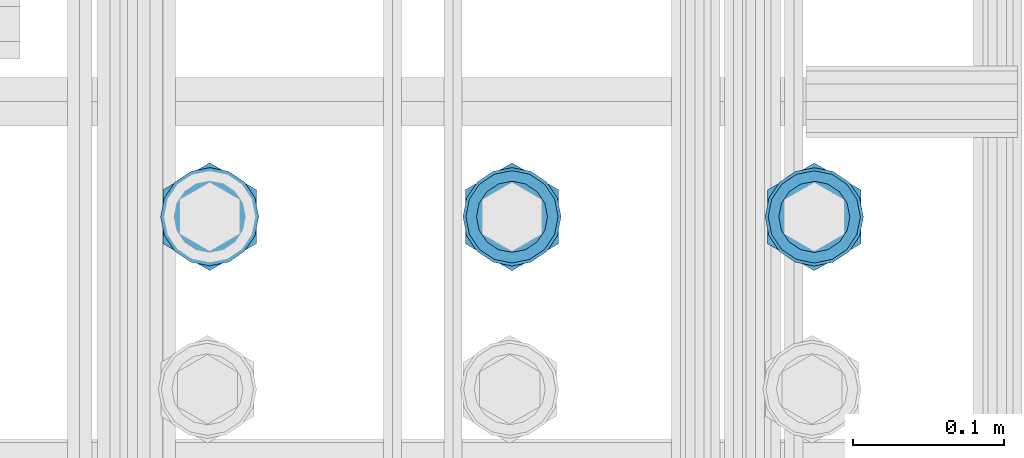
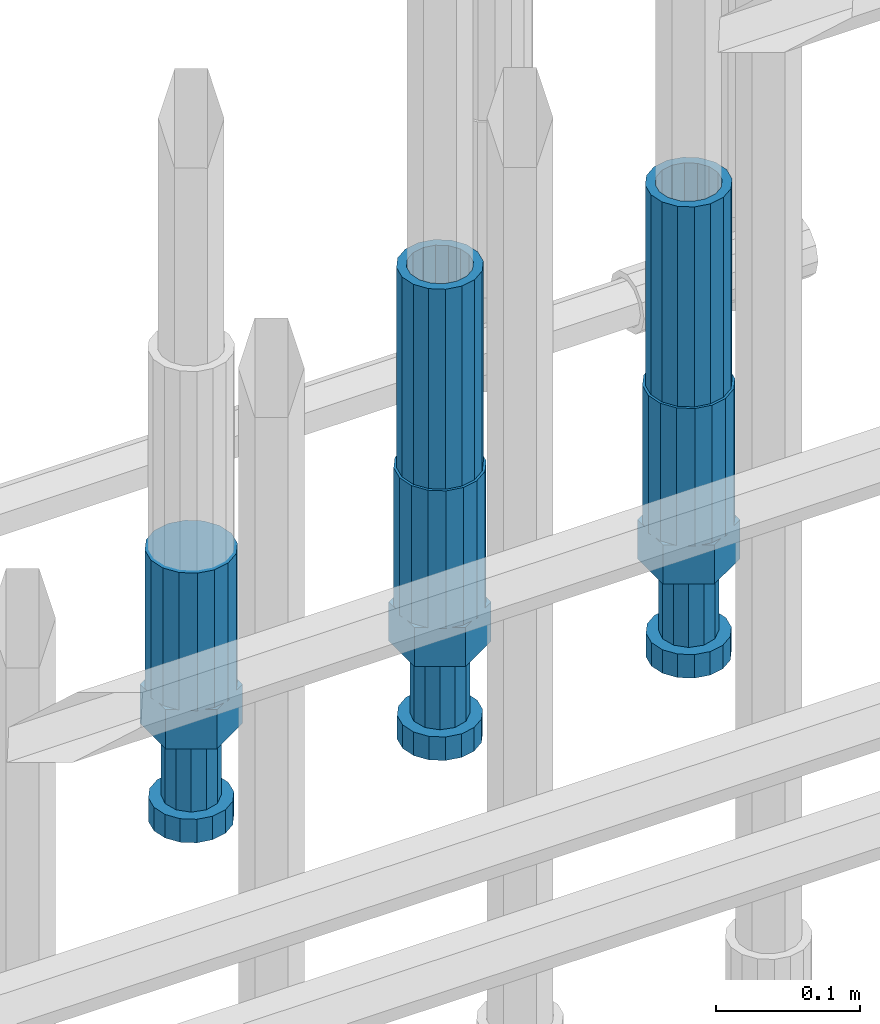
# One storey, part 41 of 177: 5 beams.
"""IFC2X3 building model written with IfcOpenShell, lengths in millimetres."""

from ifc_helpers import new_model, si_unit, frame, origin_with_axes, place, context, subcontext, project, spatial, faceted_brep, material, type_object, element, save


model = new_model("IFC2X3")

# Units and contexts
model_context_1 = context("Model", 3, precision=1e-05, world=origin_with_axes())
model_context_2 = context("Model", 3, precision=1e-05, world=origin_with_axes())
body_context = subcontext(model_context_2, "Body", "Model", "MODEL_VIEW")
ifc_project = project(units=[si_unit("LENGTHUNIT", "METRE", prefix="MILLI"), si_unit("AREAUNIT", "SQUARE_METRE"), si_unit("VOLUMEUNIT", "CUBIC_METRE"), si_unit("MASSUNIT", "GRAM", prefix="KILO"), si_unit("TIMEUNIT", "SECOND"), si_unit("PLANEANGLEUNIT", "RADIAN"), si_unit("SOLIDANGLEUNIT", "STERADIAN"), si_unit("THERMODYNAMICTEMPERATUREUNIT", "DEGREE_CELSIUS"), si_unit("LUMINOUSINTENSITYUNIT", "LUMEN")], contexts=[model_context_1])

# Site, building, storey
site_placement = place(None, origin_with_axes())
site = spatial("IfcSite", under=ifc_project, at=site_placement, CompositionType="ELEMENT")
building_placement = place(site_placement, origin_with_axes())
building = spatial("IfcBuilding", under=site, at=building_placement, Name="Undefined", CompositionType="ELEMENT")
storey_placement = place(building_placement, origin_with_axes())
storey = spatial("IfcBuildingStorey", under=building, at=storey_placement, Name="Undefined", CompositionType="ELEMENT", Elevation=0.0)

# Beams
ifc_material = material(Name="STEEL/S275")
beam_type_1 = type_object("IfcBeamType", PredefinedType="NOTDEFINED")
beam_1_placement = place(storey_placement, frame((2031575.50320246, 6205271.46363198, 19060.9768004271), z_axis=(-1.0, 0.0, 0.0), x_axis=(0.0, 0.0, -1.0)))
element("IfcBeam", 1, at=beam_1_placement, inside=storey, type_object=beam_type_1, material=ifc_material, Name="AG40N", context=body_context, shape_type="Brep", body=[
    faceted_brep([(0.0, -23.5000000001164, -9.31322574615479e-10), (0.0, -21.7111690140155, 8.99306066054851), (170.0, -21.7111690140155, 8.99306066054851), (170.0, -23.5, 0.0), (0.0, -16.6170093578839, 16.6170093575493), (170.0, -16.6170093578839, 16.6170093575493), (0.0, -8.99306066057943, 21.7111690137535), (170.0, -8.99306066057943, 21.7111690137535), (0.0, 1.16415321826935e-10, 23.5), (170.0, 0.0, 23.5), (0.0, 8.99306066057943, 21.7111690137535), (170.0, 8.99306066057943, 21.7111690137535), (0.0, 16.6170093578839, 16.6170093575493), (170.0, 16.6170093578839, 16.6170093575493), (0.0, 21.7111690140155, 8.99306066054851), (170.0, 21.7111690140155, 8.99306066054851), (0.0, 23.5000000001164, -9.31322574615479e-10), (170.0, 23.5, 0.0), (0.0, 21.7111690140155, -8.99306066054851), (170.0, 21.7111690140155, -8.99306066054851), (0.0, 16.6170093578839, -16.6170093575493), (170.0, 16.6170093578839, -16.6170093575493), (0.0, 8.99306066057943, -21.7111690137535), (170.0, 8.99306066057943, -21.7111690137535), (0.0, 1.16415321826935e-10, -23.5000000009313), (170.0, 0.0, -23.5), (0.0, -8.99306066057943, -21.7111690137535), (170.0, -8.99306066057943, -21.7111690137535), (0.0, -16.6170093578839, -16.6170093575493), (170.0, -16.6170093578839, -16.6170093575493), (0.0, -21.7111690140155, -8.99306066054851), (170.0, -21.7111690140155, -8.99306066054851), (0.0, -30.5, 0.0), (0.0, -28.1783257415937, -11.6718446873128), (170.0, -28.1783257415937, -11.6718446873128), (170.0, -30.5, 0.0), (0.0, -21.5667568261888, -21.5667568258941), (170.0, -21.5667568261888, -21.5667568258941), (0.0, -11.6718446871346, -28.1783257415518), (170.0, -11.6718446871346, -28.1783257415518), (0.0, 0.0, -30.5), (170.0, 0.0, -30.5), (0.0, 11.6718446871346, -28.1783257415518), (170.0, 11.6718446871346, -28.1783257415518), (0.0, 21.5667568261888, -21.5667568258941), (170.0, 21.5667568261888, -21.5667568258941), (0.0, 28.1783257415937, -11.6718446873128), (170.0, 28.1783257415937, -11.6718446873128), (0.0, 30.5, 0.0), (170.0, 30.5, 0.0), (0.0, 28.1783257415937, 11.6718446873128), (170.0, 28.1783257415937, 11.6718446873128), (0.0, 21.5667568261888, 21.5667568258941), (170.0, 21.5667568261888, 21.5667568258941), (0.0, 11.6718446871346, 28.1783257415518), (170.0, 11.6718446871346, 28.1783257415518), (0.0, 0.0, 30.5), (170.0, 0.0, 30.5), (0.0, -11.6718446871346, 28.1783257415518), (170.0, -11.6718446871346, 28.1783257415518), (0.0, -21.5667568261888, 21.5667568258941), (170.0, -21.5667568261888, 21.5667568258941), (0.0, -28.1783257415937, 11.6718446873128), (170.0, -28.1783257415937, 11.6718446873128)], [[[0, 1, 2, 3]], [[1, 4, 5, 2]], [[4, 6, 7, 5]], [[6, 8, 9, 7]], [[8, 10, 11, 9]], [[10, 12, 13, 11]], [[12, 14, 15, 13]], [[14, 16, 17, 15]], [[16, 18, 19, 17]], [[18, 20, 21, 19]], [[20, 22, 23, 21]], [[22, 24, 25, 23]], [[24, 26, 27, 25]], [[26, 28, 29, 27]], [[28, 30, 31, 29]], [[30, 0, 3, 31]], [[32, 33, 34, 35]], [[33, 36, 37, 34]], [[36, 38, 39, 37]], [[38, 40, 41, 39]], [[40, 42, 43, 41]], [[42, 44, 45, 43]], [[44, 46, 47, 45]], [[46, 48, 49, 47]], [[48, 50, 51, 49]], [[50, 52, 53, 51]], [[52, 54, 55, 53]], [[54, 56, 57, 55]], [[56, 58, 59, 57]], [[58, 60, 61, 59]], [[60, 62, 63, 61]], [[62, 32, 35, 63]], [[37, 39, 41, 43, 45, 47, 49, 51, 53, 55, 57, 59, 61, 63, 35, 34], [5, 7, 9, 11, 13, 15, 17, 19, 21, 23, 25, 27, 29, 31, 3, 2]], [[62, 60, 58, 56, 54, 52, 50, 48, 46, 44, 42, 40, 38, 36, 33, 32], [30, 28, 26, 24, 22, 20, 18, 16, 14, 12, 10, 8, 6, 4, 1, 0]]]),
])
beam_2_placement = place(storey_placement, frame((2031775.50319529, 6205271.41014018, 19060.9768004269), z_axis=(-1.0, 0.0, 0.0), x_axis=(0.0, 0.0, -1.0)))
element("IfcBeam", 2, at=beam_2_placement, inside=storey, type_object=beam_type_1, material=ifc_material, Name="AG40N", context=body_context, shape_type="Brep", body=[
    faceted_brep([(0.0, -23.5000000001164, -9.31322574615479e-10), (0.0, -21.7111690140155, 8.99306066054851), (170.0, -21.7111690140155, 8.99306066054851), (170.0, -23.5, 0.0), (0.0, -16.6170093578839, 16.6170093575493), (170.0, -16.6170093578839, 16.6170093575493), (0.0, -8.99306066057943, 21.7111690137535), (170.0, -8.99306066057943, 21.7111690137535), (0.0, 1.16415321826935e-10, 23.5), (170.0, 0.0, 23.5), (0.0, 8.99306066057943, 21.7111690137535), (170.0, 8.99306066057943, 21.7111690137535), (0.0, 16.6170093578839, 16.6170093575493), (170.0, 16.6170093578839, 16.6170093575493), (0.0, 21.7111690140155, 8.99306066054851), (170.0, 21.7111690140155, 8.99306066054851), (0.0, 23.5000000001164, -9.31322574615479e-10), (170.0, 23.5, 0.0), (0.0, 21.7111690140155, -8.99306066054851), (170.0, 21.7111690140155, -8.99306066054851), (0.0, 16.6170093578839, -16.6170093575493), (170.0, 16.6170093578839, -16.6170093575493), (0.0, 8.99306066057943, -21.7111690137535), (170.0, 8.99306066057943, -21.7111690137535), (0.0, 1.16415321826935e-10, -23.5000000009313), (170.0, 0.0, -23.5), (0.0, -8.99306066057943, -21.7111690137535), (170.0, -8.99306066057943, -21.7111690137535), (0.0, -16.6170093578839, -16.6170093575493), (170.0, -16.6170093578839, -16.6170093575493), (0.0, -21.7111690140155, -8.99306066054851), (170.0, -21.7111690140155, -8.99306066054851), (0.0, -30.5, 0.0), (0.0, -28.1783257415937, -11.6718446873128), (170.0, -28.1783257415937, -11.6718446873128), (170.0, -30.5, 0.0), (0.0, -21.5667568261888, -21.5667568258941), (170.0, -21.5667568261888, -21.5667568258941), (0.0, -11.6718446871346, -28.1783257415518), (170.0, -11.6718446871346, -28.1783257415518), (0.0, 0.0, -30.5), (170.0, 0.0, -30.5), (0.0, 11.6718446871346, -28.1783257415518), (170.0, 11.6718446871346, -28.1783257415518), (0.0, 21.5667568261888, -21.5667568258941), (170.0, 21.5667568261888, -21.5667568258941), (0.0, 28.1783257415937, -11.6718446873128), (170.0, 28.1783257415937, -11.6718446873128), (0.0, 30.5, 0.0), (170.0, 30.5, 0.0), (0.0, 28.1783257415937, 11.6718446873128), (170.0, 28.1783257415937, 11.6718446873128), (0.0, 21.5667568261888, 21.5667568258941), (170.0, 21.5667568261888, 21.5667568258941), (0.0, 11.6718446871346, 28.1783257415518), (170.0, 11.6718446871346, 28.1783257415518), (0.0, 0.0, 30.5), (170.0, 0.0, 30.5), (0.0, -11.6718446871346, 28.1783257415518), (170.0, -11.6718446871346, 28.1783257415518), (0.0, -21.5667568261888, 21.5667568258941), (170.0, -21.5667568261888, 21.5667568258941), (0.0, -28.1783257415937, 11.6718446873128), (170.0, -28.1783257415937, 11.6718446873128)], [[[0, 1, 2, 3]], [[1, 4, 5, 2]], [[4, 6, 7, 5]], [[6, 8, 9, 7]], [[8, 10, 11, 9]], [[10, 12, 13, 11]], [[12, 14, 15, 13]], [[14, 16, 17, 15]], [[16, 18, 19, 17]], [[18, 20, 21, 19]], [[20, 22, 23, 21]], [[22, 24, 25, 23]], [[24, 26, 27, 25]], [[26, 28, 29, 27]], [[28, 30, 31, 29]], [[30, 0, 3, 31]], [[32, 33, 34, 35]], [[33, 36, 37, 34]], [[36, 38, 39, 37]], [[38, 40, 41, 39]], [[40, 42, 43, 41]], [[42, 44, 45, 43]], [[44, 46, 47, 45]], [[46, 48, 49, 47]], [[48, 50, 51, 49]], [[50, 52, 53, 51]], [[52, 54, 55, 53]], [[54, 56, 57, 55]], [[56, 58, 59, 57]], [[58, 60, 61, 59]], [[60, 62, 63, 61]], [[62, 32, 35, 63]], [[37, 39, 41, 43, 45, 47, 49, 51, 53, 55, 57, 59, 61, 63, 35, 34], [5, 7, 9, 11, 13, 15, 17, 19, 21, 23, 25, 27, 29, 31, 3, 2]], [[62, 60, 58, 56, 54, 52, 50, 48, 46, 44, 42, 40, 38, 36, 33, 32], [30, 28, 26, 24, 22, 20, 18, 16, 14, 12, 10, 8, 6, 4, 1, 0]]]),
])
beam_type_2 = type_object("IfcBeamType", Name="ROD65", PredefinedType="NOTDEFINED")
beam_3_placement = place(storey_placement, frame((2031375.50320962, 6205271.51712378, 18890.9768004272), z_axis=(-1.0, 0.0, 0.0), x_axis=(0.0, 0.0, -1.0)))
element("IfcBeam", 3, at=beam_3_placement, inside=storey, type_object=beam_type_2, material=ifc_material, Name="AGB40", ObjectType="ROD65", context=body_context, shape_type="Brep", body=[
    faceted_brep([(117.0, 8.17543110251427, 30.873805644922), (117.0, 17.8250000001863, 30.873805644922), (117.0, 22.0056958701462, 23.6326279877685), (117.0, 12.4372115517035, 30.0260848065373), (117.0, -17.8250000001863, 30.873805644922), (150.200000000186, -17.8250000001863, 30.873805644922), (150.200000000186, 17.8250000001863, 30.873805644922), (117.0, -8.17543110251427, 30.873805644922), (117.0, -12.4372115517035, 30.0260848065373), (117.0, -22.0056958701462, 23.6326279877685), (117.0, -35.6500000003725, 0.0), (150.200000000186, -35.6500000003725, 0.0), (117.0, -30.8443150008097, 8.32369058486074), (117.0, -32.5, 0.0), (117.0, -30.8443150008097, -8.32369058462791), (117.0, -17.8250000001863, -30.873805644922), (150.200000000186, -17.8250000001863, -30.873805644922), (117.0, -22.0056958701462, -23.6326279877685), (117.0, -12.4372115517035, -30.0260848065373), (117.0, -8.17543110251427, -30.873805644922), (117.0, 17.8250000001863, -30.873805644922), (150.200000000186, 17.8250000001863, -30.873805644922), (117.0, 8.17543110251427, -30.873805644922), (117.0, 22.0056958701462, -23.6326279877685), (117.0, 12.4372115517035, -30.0260848065373), (117.0, 35.6500000003725, 0.0), (150.200000000186, 35.6500000003725, 0.0), (117.0, 30.8443150008097, -8.32369058486074), (117.0, 30.8443150008097, 8.32369058462791), (117.0, 32.5, 0.0), (0.0, -22.9809703892097, 22.9809703885621), (0.0, -30.0260848058388, 12.4372115518636), (117.0, -30.0260848067701, 12.4372115519363), (117.0, -22.9809703882784, 22.9809703885112), (-2.3283064365387e-10, 22.9809703892097, -22.9809703885639), (-4.65661287307739e-10, 30.0260848077014, -12.4372115518672), (117.0, 30.0260848067701, -12.4372115519363), (117.0, 22.9809703882784, -22.9809703885112), (-2.3283064365387e-10, -30.0260848067701, -12.4372115518672), (-2.3283064365387e-10, -22.9809703892097, -22.9809703885621), (117.0, -22.9809703882784, -22.9809703885112), (117.0, -30.0260848067701, -12.4372115519363), (-2.3283064365387e-10, -12.4372115507722, 30.0260848066137), (-2.3283064365387e-10, 9.31322574615479e-10, 32.4999999999982), (-2.3283064365387e-10, 12.4372115526348, 30.0260848066137), (0.0, 22.9809703892097, 22.9809703885621), (-2.3283064365387e-10, 30.0260848077014, 12.4372115518636), (-2.3283064365387e-10, 32.5, 0.0), (-2.3283064365387e-10, 12.4372115526348, -30.0260848066173), (-2.3283064365387e-10, 9.31322574615479e-10, -32.5), (-2.3283064365387e-10, -12.4372115517035, -30.0260848066173), (-4.65661287307739e-10, -32.4999999990687, -1.81898940354586e-12), (117.0, 22.9809703882784, 22.9809703885112), (117.0, 30.0260848067701, 12.4372115519363), (117.0, 0.0, -32.5), (117.0, 0.0, 32.5), (150.200000000186, 10.5, -18.1865334794857), (150.200000000186, 0.0, -21.0), (150.200000000186, -10.5, -18.1865334794857), (150.200000000186, -18.18653347902, -10.5), (150.200000000186, -21.0, 0.0), (150.200000000186, -18.18653347902, 10.5), (150.200000000186, -10.5, 18.1865334794857), (150.200000000186, 0.0, 21.0), (150.200000000186, 10.5, 18.1865334794857), (150.200000000186, 18.18653347902, 10.5), (150.200000000186, 21.0, 0.0), (150.200000000186, 18.18653347902, -10.5), (210.980000000447, -10.5, -18.1865334794857), (210.980000000447, 0.0, -21.0), (210.980000000447, -18.18653347902, -10.5), (210.980000000447, -21.0, 0.0), (210.980000000447, -18.18653347902, 10.5), (210.980000000447, -10.5, 18.1865334794857), (210.980000000447, 0.0, 21.0), (210.980000000447, 10.5, 18.1865334794857), (210.980000000447, 18.18653347902, 10.5), (210.980000000447, 21.0, 0.0), (210.980000000447, 18.18653347902, -10.5), (210.980000000447, 10.5, -18.1865334794857), (211.001368442696, -27.7269937992096, -11.491116326768), (211.003082550167, -21.2238094303757, -21.223815418547), (231.002518367059, -21.2131944671273, -21.2132004550658), (231.000804259587, -27.7163788359612, -11.4805013632867), (211.001368440451, -11.4911085031927, -27.7269970395137), (231.000804257343, -11.4804935399443, -27.7163820760325), (210.996487071217, -0.0106065049767494, -30.0106107392348), (230.995922888109, 8.45827162265778e-06, -29.9999957757536), (210.989181586672, 11.46989420522, -27.7269970329944), (230.988617403564, 11.4805091684684, -27.7163820695132), (210.980564180623, 21.2025914648548, -21.2238154064398), (230.979999997515, 21.2132064281031, -21.2132004429586), (210.971946775022, 27.7057703435421, -11.4911163107026), (230.971382591913, 27.7163853067905, -11.4805013472214), (210.96464129175, 29.9893808094785, -0.0106149562634528), (230.964077108642, 29.9999957727268, 7.21774995326996e-09), (210.959759924415, 27.7057638689876, 11.4698863970116), (230.959195741307, 27.7163788322359, 11.4805013604928), (210.958045816944, 21.2025795001537, 21.2025854887906), (230.957481633835, 21.213194463402, 21.2132004522718), (210.95975992666, 11.4698785729706, 27.7057671097573), (230.959195743551, 11.480493536219, 27.7163820732385), (210.964641295894, -0.010623425245285, 29.9893808094785), (230.964077112785, -8.46199691295624e-06, 29.9999957729597), (210.971946780439, -11.4911241354421, 27.705767103238), (230.97138259733, -11.4805091721937, 27.7163820667192), (210.980564186488, -21.2238213950768, 21.2025854766835), (230.980000003379, -21.2132064318284, 21.2132004401647), (210.989181592089, -27.7270002737641, 11.4698863809463), (230.988617408981, -27.7163853105158, 11.4805013444275), (210.996487075361, -30.0106107397005, -0.0106149734929204), (230.995922892253, -29.9999957764521, -1.00117176771164e-08)], [[[0, 1, 2, 3]], [[4, 5, 6, 1, 0, 7]], [[4, 7, 8, 9]], [[10, 11, 5, 4, 9, 12]], [[10, 12, 13, 14]], [[15, 16, 11, 10, 14, 17]], [[15, 17, 18, 19]], [[20, 21, 16, 15, 19, 22]], [[23, 20, 22, 24]], [[25, 26, 21, 20, 23, 27]], [[28, 25, 27, 29]], [[30, 31, 32, 33]], [[34, 35, 36, 37]], [[38, 39, 40, 41]], [[31, 30, 42, 43, 44, 45, 46, 47, 35, 34, 48, 49, 50, 39, 38, 51]], [[46, 45, 52, 53]], [[29, 47, 46, 53, 28]], [[27, 36, 35, 47, 29]], [[23, 37, 36, 27]], [[24, 48, 34, 37, 23]], [[22, 54, 49, 48, 24]], [[19, 54, 22]], [[18, 50, 49, 54, 19]], [[17, 40, 39, 50, 18]], [[14, 41, 40, 17]], [[13, 51, 38, 41, 14]], [[12, 32, 31, 51, 13]], [[9, 33, 32, 12]], [[8, 42, 30, 33, 9]], [[7, 55, 43, 42, 8]], [[0, 55, 7]], [[3, 44, 43, 55, 0]], [[2, 52, 45, 44, 3]], [[28, 53, 52, 2]], [[1, 6, 26, 25, 28, 2]], [[5, 11, 16, 21, 26, 6], [56, 57, 58, 59, 60, 61, 62, 63, 64, 65, 66, 67]], [[68, 58, 57, 69]], [[70, 59, 58, 68]], [[71, 60, 59, 70]], [[72, 61, 60, 71]], [[73, 62, 61, 72]], [[74, 63, 62, 73]], [[75, 64, 63, 74]], [[76, 65, 64, 75]], [[77, 66, 65, 76]], [[78, 67, 66, 77]], [[79, 56, 67, 78]], [[69, 57, 56, 79]], [[80, 81, 82, 83]], [[81, 84, 85, 82]], [[84, 86, 87, 85]], [[86, 88, 89, 87]], [[88, 90, 91, 89]], [[90, 92, 93, 91]], [[92, 94, 95, 93]], [[94, 96, 97, 95]], [[96, 98, 99, 97]], [[98, 100, 101, 99]], [[100, 102, 103, 101]], [[102, 104, 105, 103]], [[104, 106, 107, 105]], [[106, 108, 109, 107]], [[108, 110, 111, 109]], [[82, 85, 87, 89, 91, 93, 95, 97, 99, 101, 103, 105, 107, 109, 111, 83]], [[110, 80, 83, 111]], [[108, 106, 104, 102, 100, 98, 96, 94, 92, 90, 88, 86, 84, 81, 80, 110], [78, 77, 76, 75, 74, 73, 72, 71, 70, 68, 69, 79]]]),
])
beam_4_placement = place(storey_placement, frame((2031575.50320245, 6205271.46363198, 18890.9768004271), z_axis=(-1.0, 0.0, 0.0), x_axis=(0.0, 0.0, -1.0)))
element("IfcBeam", 4, at=beam_4_placement, inside=storey, type_object=beam_type_2, material=ifc_material, Name="AGB40", ObjectType="ROD65", context=body_context, shape_type="Brep", body=[
    faceted_brep([(117.0, 8.17543110251427, 30.873805644922), (117.0, 17.8250000001863, 30.873805644922), (117.0, 22.0056958701462, 23.6326279877685), (117.0, 12.4372115517035, 30.0260848065373), (117.0, -17.8250000001863, 30.873805644922), (150.200000000186, -17.8250000001863, 30.873805644922), (150.200000000186, 17.8250000001863, 30.873805644922), (117.0, -8.17543110251427, 30.873805644922), (117.0, -12.4372115517035, 30.0260848065373), (117.0, -22.0056958701462, 23.6326279877685), (117.0, -35.6500000003725, 0.0), (150.200000000186, -35.6500000003725, 0.0), (117.0, -30.8443150008097, 8.32369058486074), (117.0, -32.5, 0.0), (117.0, -30.8443150008097, -8.32369058462791), (117.0, -17.8250000001863, -30.873805644922), (150.200000000186, -17.8250000001863, -30.873805644922), (117.0, -22.0056958701462, -23.6326279877685), (117.0, -12.4372115517035, -30.0260848065373), (117.0, -8.17543110251427, -30.873805644922), (117.0, 17.8250000001863, -30.873805644922), (150.200000000186, 17.8250000001863, -30.873805644922), (117.0, 8.17543110251427, -30.873805644922), (117.0, 22.0056958701462, -23.6326279877685), (117.0, 12.4372115517035, -30.0260848065373), (117.0, 35.6500000003725, 0.0), (150.200000000186, 35.6500000003725, 0.0), (117.0, 30.8443150008097, -8.32369058486074), (117.0, 30.8443150008097, 8.32369058462791), (117.0, 32.5, 0.0), (0.0, -22.9809703892097, 22.9809703885621), (0.0, -30.0260848058388, 12.4372115518636), (117.0, -30.0260848067701, 12.4372115519363), (117.0, -22.9809703882784, 22.9809703885112), (-2.3283064365387e-10, 22.9809703892097, -22.9809703885639), (-4.65661287307739e-10, 30.0260848077014, -12.4372115518672), (117.0, 30.0260848067701, -12.4372115519363), (117.0, 22.9809703882784, -22.9809703885112), (-2.3283064365387e-10, -30.0260848067701, -12.4372115518672), (-2.3283064365387e-10, -22.9809703892097, -22.9809703885621), (117.0, -22.9809703882784, -22.9809703885112), (117.0, -30.0260848067701, -12.4372115519363), (-2.3283064365387e-10, -12.4372115507722, 30.0260848066137), (-2.3283064365387e-10, 9.31322574615479e-10, 32.4999999999982), (-2.3283064365387e-10, 12.4372115526348, 30.0260848066137), (0.0, 22.9809703892097, 22.9809703885621), (-2.3283064365387e-10, 30.0260848077014, 12.4372115518636), (-2.3283064365387e-10, 32.5, 0.0), (-2.3283064365387e-10, 12.4372115526348, -30.0260848066173), (-2.3283064365387e-10, 9.31322574615479e-10, -32.5), (-2.3283064365387e-10, -12.4372115517035, -30.0260848066173), (-4.65661287307739e-10, -32.4999999990687, -1.81898940354586e-12), (117.0, 22.9809703882784, 22.9809703885112), (117.0, 30.0260848067701, 12.4372115519363), (117.0, 0.0, -32.5), (117.0, 0.0, 32.5), (150.200000000186, 10.5, -18.1865334794857), (150.200000000186, 0.0, -21.0), (150.200000000186, -10.5, -18.1865334794857), (150.200000000186, -18.18653347902, -10.5), (150.200000000186, -21.0, 0.0), (150.200000000186, -18.18653347902, 10.5), (150.200000000186, -10.5, 18.1865334794857), (150.200000000186, 0.0, 21.0), (150.200000000186, 10.5, 18.1865334794857), (150.200000000186, 18.18653347902, 10.5), (150.200000000186, 21.0, 0.0), (150.200000000186, 18.18653347902, -10.5), (210.980000000447, -10.5, -18.1865334794857), (210.980000000447, 0.0, -21.0), (210.980000000447, -18.18653347902, -10.5), (210.980000000447, -21.0, 0.0), (210.980000000447, -18.18653347902, 10.5), (210.980000000447, -10.5, 18.1865334794857), (210.980000000447, 0.0, 21.0), (210.980000000447, 10.5, 18.1865334794857), (210.980000000447, 18.18653347902, 10.5), (210.980000000447, 21.0, 0.0), (210.980000000447, 18.18653347902, -10.5), (210.980000000447, 10.5, -18.1865334794857), (211.001368442696, -27.7269937992096, -11.491116326768), (211.003082550167, -21.2238094303757, -21.223815418547), (231.002518367059, -21.2131944671273, -21.2132004550658), (231.000804259587, -27.7163788359612, -11.4805013632867), (211.001368440451, -11.4911085031927, -27.7269970395137), (231.000804257343, -11.4804935399443, -27.7163820760325), (210.996487071217, -0.0106065049767494, -30.0106107392348), (230.995922888109, 8.45827162265778e-06, -29.9999957757536), (210.989181586672, 11.46989420522, -27.7269970329944), (230.988617403564, 11.4805091684684, -27.7163820695132), (210.980564180623, 21.2025914648548, -21.2238154064398), (230.979999997515, 21.2132064281031, -21.2132004429586), (210.971946775022, 27.7057703435421, -11.4911163107026), (230.971382591913, 27.7163853067905, -11.4805013472214), (210.96464129175, 29.9893808094785, -0.0106149562634528), (230.964077108642, 29.9999957727268, 7.21774995326996e-09), (210.959759924415, 27.7057638689876, 11.4698863970116), (230.959195741307, 27.7163788322359, 11.4805013604928), (210.958045816944, 21.2025795001537, 21.2025854887906), (230.957481633835, 21.213194463402, 21.2132004522718), (210.95975992666, 11.4698785729706, 27.7057671097573), (230.959195743551, 11.480493536219, 27.7163820732385), (210.964641295894, -0.010623425245285, 29.9893808094785), (230.964077112785, -8.46199691295624e-06, 29.9999957729597), (210.971946780439, -11.4911241354421, 27.705767103238), (230.97138259733, -11.4805091721937, 27.7163820667192), (210.980564186488, -21.2238213950768, 21.2025854766835), (230.980000003379, -21.2132064318284, 21.2132004401647), (210.989181592089, -27.7270002737641, 11.4698863809463), (230.988617408981, -27.7163853105158, 11.4805013444275), (210.996487075361, -30.0106107397005, -0.0106149734929204), (230.995922892253, -29.9999957764521, -1.00117176771164e-08)], [[[0, 1, 2, 3]], [[4, 5, 6, 1, 0, 7]], [[4, 7, 8, 9]], [[10, 11, 5, 4, 9, 12]], [[10, 12, 13, 14]], [[15, 16, 11, 10, 14, 17]], [[15, 17, 18, 19]], [[20, 21, 16, 15, 19, 22]], [[23, 20, 22, 24]], [[25, 26, 21, 20, 23, 27]], [[28, 25, 27, 29]], [[30, 31, 32, 33]], [[34, 35, 36, 37]], [[38, 39, 40, 41]], [[31, 30, 42, 43, 44, 45, 46, 47, 35, 34, 48, 49, 50, 39, 38, 51]], [[46, 45, 52, 53]], [[29, 47, 46, 53, 28]], [[27, 36, 35, 47, 29]], [[23, 37, 36, 27]], [[24, 48, 34, 37, 23]], [[22, 54, 49, 48, 24]], [[19, 54, 22]], [[18, 50, 49, 54, 19]], [[17, 40, 39, 50, 18]], [[14, 41, 40, 17]], [[13, 51, 38, 41, 14]], [[12, 32, 31, 51, 13]], [[9, 33, 32, 12]], [[8, 42, 30, 33, 9]], [[7, 55, 43, 42, 8]], [[0, 55, 7]], [[3, 44, 43, 55, 0]], [[2, 52, 45, 44, 3]], [[28, 53, 52, 2]], [[1, 6, 26, 25, 28, 2]], [[5, 11, 16, 21, 26, 6], [56, 57, 58, 59, 60, 61, 62, 63, 64, 65, 66, 67]], [[68, 58, 57, 69]], [[70, 59, 58, 68]], [[71, 60, 59, 70]], [[72, 61, 60, 71]], [[73, 62, 61, 72]], [[74, 63, 62, 73]], [[75, 64, 63, 74]], [[76, 65, 64, 75]], [[77, 66, 65, 76]], [[78, 67, 66, 77]], [[79, 56, 67, 78]], [[69, 57, 56, 79]], [[80, 81, 82, 83]], [[81, 84, 85, 82]], [[84, 86, 87, 85]], [[86, 88, 89, 87]], [[88, 90, 91, 89]], [[90, 92, 93, 91]], [[92, 94, 95, 93]], [[94, 96, 97, 95]], [[96, 98, 99, 97]], [[98, 100, 101, 99]], [[100, 102, 103, 101]], [[102, 104, 105, 103]], [[104, 106, 107, 105]], [[106, 108, 109, 107]], [[108, 110, 111, 109]], [[82, 85, 87, 89, 91, 93, 95, 97, 99, 101, 103, 105, 107, 109, 111, 83]], [[110, 80, 83, 111]], [[108, 106, 104, 102, 100, 98, 96, 94, 92, 90, 88, 86, 84, 81, 80, 110], [78, 77, 76, 75, 74, 73, 72, 71, 70, 68, 69, 79]]]),
])
beam_5_placement = place(storey_placement, frame((2031775.50319528, 6205271.41014018, 18890.9768004269), z_axis=(-1.0, 0.0, 0.0), x_axis=(0.0, 0.0, -1.0)))
element("IfcBeam", 5, at=beam_5_placement, inside=storey, type_object=beam_type_2, material=ifc_material, Name="AGB40", ObjectType="ROD65", context=body_context, shape_type="Brep", body=[
    faceted_brep([(117.0, 8.17543110251427, 30.873805644922), (117.0, 17.8250000001863, 30.873805644922), (117.0, 22.0056958701462, 23.6326279877685), (117.0, 12.4372115517035, 30.0260848065373), (117.0, -17.8250000001863, 30.873805644922), (150.200000000186, -17.8250000001863, 30.873805644922), (150.200000000186, 17.8250000001863, 30.873805644922), (117.0, -8.17543110251427, 30.873805644922), (117.0, -12.4372115517035, 30.0260848065373), (117.0, -22.0056958701462, 23.6326279877685), (117.0, -35.6500000003725, 0.0), (150.200000000186, -35.6500000003725, 0.0), (117.0, -30.8443150008097, 8.32369058486074), (117.0, -32.5, 0.0), (117.0, -30.8443150008097, -8.32369058462791), (117.0, -17.8250000001863, -30.873805644922), (150.200000000186, -17.8250000001863, -30.873805644922), (117.0, -22.0056958701462, -23.6326279877685), (117.0, -12.4372115517035, -30.0260848065373), (117.0, -8.17543110251427, -30.873805644922), (117.0, 17.8250000001863, -30.873805644922), (150.200000000186, 17.8250000001863, -30.873805644922), (117.0, 8.17543110251427, -30.873805644922), (117.0, 22.0056958701462, -23.6326279877685), (117.0, 12.4372115517035, -30.0260848065373), (117.0, 35.6500000003725, 0.0), (150.200000000186, 35.6500000003725, 0.0), (117.0, 30.8443150008097, -8.32369058486074), (117.0, 30.8443150008097, 8.32369058462791), (117.0, 32.5, 0.0), (0.0, -22.9809703892097, 22.9809703885621), (0.0, -30.0260848058388, 12.4372115518636), (117.0, -30.0260848067701, 12.4372115519363), (117.0, -22.9809703882784, 22.9809703885112), (-2.3283064365387e-10, 22.9809703892097, -22.9809703885639), (-4.65661287307739e-10, 30.0260848077014, -12.4372115518672), (117.0, 30.0260848067701, -12.4372115519363), (117.0, 22.9809703882784, -22.9809703885112), (-2.3283064365387e-10, -30.0260848067701, -12.4372115518672), (-2.3283064365387e-10, -22.9809703892097, -22.9809703885621), (117.0, -22.9809703882784, -22.9809703885112), (117.0, -30.0260848067701, -12.4372115519363), (-2.3283064365387e-10, -12.4372115507722, 30.0260848066137), (-2.3283064365387e-10, 9.31322574615479e-10, 32.4999999999982), (-2.3283064365387e-10, 12.4372115526348, 30.0260848066137), (0.0, 22.9809703892097, 22.9809703885621), (-2.3283064365387e-10, 30.0260848077014, 12.4372115518636), (-2.3283064365387e-10, 32.5, 0.0), (-2.3283064365387e-10, 12.4372115526348, -30.0260848066173), (-2.3283064365387e-10, 9.31322574615479e-10, -32.5), (-2.3283064365387e-10, -12.4372115517035, -30.0260848066173), (-4.65661287307739e-10, -32.4999999990687, -1.81898940354586e-12), (117.0, 22.9809703882784, 22.9809703885112), (117.0, 30.0260848067701, 12.4372115519363), (117.0, 0.0, -32.5), (117.0, 0.0, 32.5), (150.200000000186, 10.5, -18.1865334794857), (150.200000000186, 0.0, -21.0), (150.200000000186, -10.5, -18.1865334794857), (150.200000000186, -18.18653347902, -10.5), (150.200000000186, -21.0, 0.0), (150.200000000186, -18.18653347902, 10.5), (150.200000000186, -10.5, 18.1865334794857), (150.200000000186, 0.0, 21.0), (150.200000000186, 10.5, 18.1865334794857), (150.200000000186, 18.18653347902, 10.5), (150.200000000186, 21.0, 0.0), (150.200000000186, 18.18653347902, -10.5), (210.980000000447, -10.5, -18.1865334794857), (210.980000000447, 0.0, -21.0), (210.980000000447, -18.18653347902, -10.5), (210.980000000447, -21.0, 0.0), (210.980000000447, -18.18653347902, 10.5), (210.980000000447, -10.5, 18.1865334794857), (210.980000000447, 0.0, 21.0), (210.980000000447, 10.5, 18.1865334794857), (210.980000000447, 18.18653347902, 10.5), (210.980000000447, 21.0, 0.0), (210.980000000447, 18.18653347902, -10.5), (210.980000000447, 10.5, -18.1865334794857), (211.001368442696, -27.7269937992096, -11.491116326768), (211.003082550167, -21.2238094303757, -21.223815418547), (231.002518367059, -21.2131944671273, -21.2132004550658), (231.000804259587, -27.7163788359612, -11.4805013632867), (211.001368440451, -11.4911085031927, -27.7269970395137), (231.000804257343, -11.4804935399443, -27.7163820760325), (210.996487071217, -0.0106065049767494, -30.0106107392348), (230.995922888109, 8.45827162265778e-06, -29.9999957757536), (210.989181586672, 11.46989420522, -27.7269970329944), (230.988617403564, 11.4805091684684, -27.7163820695132), (210.980564180623, 21.2025914648548, -21.2238154064398), (230.979999997515, 21.2132064281031, -21.2132004429586), (210.971946775022, 27.7057703435421, -11.4911163107026), (230.971382591913, 27.7163853067905, -11.4805013472214), (210.96464129175, 29.9893808094785, -0.0106149562634528), (230.964077108642, 29.9999957727268, 7.21774995326996e-09), (210.959759924415, 27.7057638689876, 11.4698863970116), (230.959195741307, 27.7163788322359, 11.4805013604928), (210.958045816944, 21.2025795001537, 21.2025854887906), (230.957481633835, 21.213194463402, 21.2132004522718), (210.95975992666, 11.4698785729706, 27.7057671097573), (230.959195743551, 11.480493536219, 27.7163820732385), (210.964641295894, -0.010623425245285, 29.9893808094785), (230.964077112785, -8.46199691295624e-06, 29.9999957729597), (210.971946780439, -11.4911241354421, 27.705767103238), (230.97138259733, -11.4805091721937, 27.7163820667192), (210.980564186488, -21.2238213950768, 21.2025854766835), (230.980000003379, -21.2132064318284, 21.2132004401647), (210.989181592089, -27.7270002737641, 11.4698863809463), (230.988617408981, -27.7163853105158, 11.4805013444275), (210.996487075361, -30.0106107397005, -0.0106149734929204), (230.995922892253, -29.9999957764521, -1.00117176771164e-08)], [[[0, 1, 2, 3]], [[4, 5, 6, 1, 0, 7]], [[4, 7, 8, 9]], [[10, 11, 5, 4, 9, 12]], [[10, 12, 13, 14]], [[15, 16, 11, 10, 14, 17]], [[15, 17, 18, 19]], [[20, 21, 16, 15, 19, 22]], [[23, 20, 22, 24]], [[25, 26, 21, 20, 23, 27]], [[28, 25, 27, 29]], [[30, 31, 32, 33]], [[34, 35, 36, 37]], [[38, 39, 40, 41]], [[31, 30, 42, 43, 44, 45, 46, 47, 35, 34, 48, 49, 50, 39, 38, 51]], [[46, 45, 52, 53]], [[29, 47, 46, 53, 28]], [[27, 36, 35, 47, 29]], [[23, 37, 36, 27]], [[24, 48, 34, 37, 23]], [[22, 54, 49, 48, 24]], [[19, 54, 22]], [[18, 50, 49, 54, 19]], [[17, 40, 39, 50, 18]], [[14, 41, 40, 17]], [[13, 51, 38, 41, 14]], [[12, 32, 31, 51, 13]], [[9, 33, 32, 12]], [[8, 42, 30, 33, 9]], [[7, 55, 43, 42, 8]], [[0, 55, 7]], [[3, 44, 43, 55, 0]], [[2, 52, 45, 44, 3]], [[28, 53, 52, 2]], [[1, 6, 26, 25, 28, 2]], [[5, 11, 16, 21, 26, 6], [56, 57, 58, 59, 60, 61, 62, 63, 64, 65, 66, 67]], [[68, 58, 57, 69]], [[70, 59, 58, 68]], [[71, 60, 59, 70]], [[72, 61, 60, 71]], [[73, 62, 61, 72]], [[74, 63, 62, 73]], [[75, 64, 63, 74]], [[76, 65, 64, 75]], [[77, 66, 65, 76]], [[78, 67, 66, 77]], [[79, 56, 67, 78]], [[69, 57, 56, 79]], [[80, 81, 82, 83]], [[81, 84, 85, 82]], [[84, 86, 87, 85]], [[86, 88, 89, 87]], [[88, 90, 91, 89]], [[90, 92, 93, 91]], [[92, 94, 95, 93]], [[94, 96, 97, 95]], [[96, 98, 99, 97]], [[98, 100, 101, 99]], [[100, 102, 103, 101]], [[102, 104, 105, 103]], [[104, 106, 107, 105]], [[106, 108, 109, 107]], [[108, 110, 111, 109]], [[82, 85, 87, 89, 91, 93, 95, 97, 99, 101, 103, 105, 107, 109, 111, 83]], [[110, 80, 83, 111]], [[108, 106, 104, 102, 100, 98, 96, 94, 92, 90, 88, 86, 84, 81, 80, 110], [78, 77, 76, 75, 74, 73, 72, 71, 70, 68, 69, 79]]]),
])

save(model, "model.ifc")
